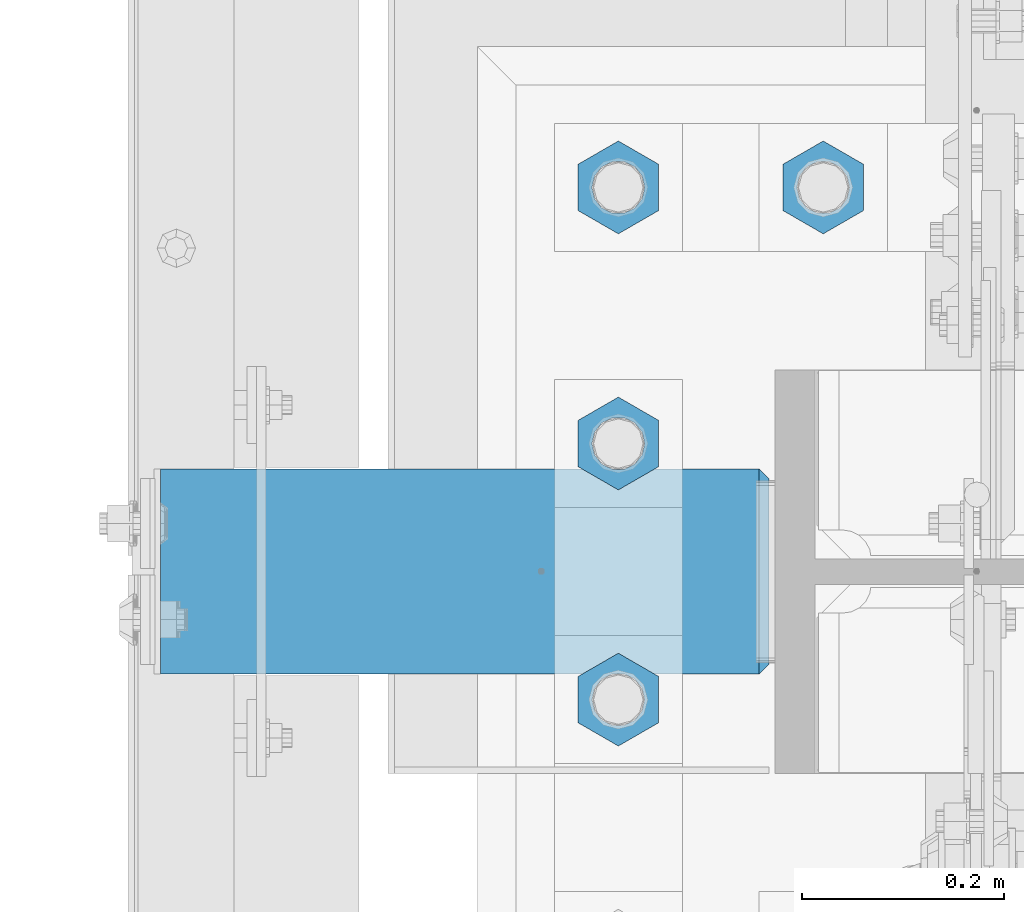
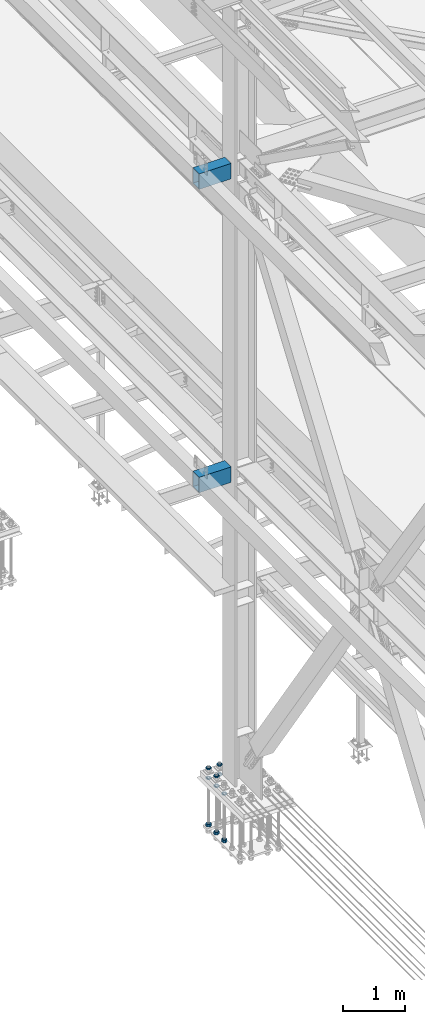
# One storey, part 2214 of 3843: 12 beams, 2 elements without a shape of their own.
"""IFC2X3 building model written with IfcOpenShell, lengths in millimetres."""

from ifc_helpers import new_model, si_unit, frame, origin_with_axes, place, context, subcontext, project, spatial, faceted_brep, material, type_object, element, aggregate, save


model = new_model("IFC2X3")

# Units and contexts
model_context = context("Model", 3, precision=1e-05, world=origin_with_axes())
body_context = subcontext(model_context, "Body", "Model", "MODEL_VIEW")
ifc_project = project(units=[si_unit("LENGTHUNIT", "METRE", prefix="MILLI"), si_unit("AREAUNIT", "SQUARE_METRE"), si_unit("VOLUMEUNIT", "CUBIC_METRE"), si_unit("MASSUNIT", "GRAM", prefix="KILO"), si_unit("TIMEUNIT", "SECOND"), si_unit("PLANEANGLEUNIT", "RADIAN"), si_unit("SOLIDANGLEUNIT", "STERADIAN"), si_unit("THERMODYNAMICTEMPERATUREUNIT", "DEGREE_CELSIUS"), si_unit("LUMINOUSINTENSITYUNIT", "LUMEN")], contexts=[model_context])

# Site, building, storey
site_placement = place(None, origin_with_axes())
site = spatial("IfcSite", under=ifc_project, at=site_placement, CompositionType="ELEMENT")
building_placement = place(site_placement, origin_with_axes())
building = spatial("IfcBuilding", under=site, at=building_placement, Name="Undefined", CompositionType="ELEMENT")
storey_placement = place(building_placement, origin_with_axes())
storey = spatial("IfcBuildingStorey", under=building, at=storey_placement, Name="Undefined", CompositionType="ELEMENT", Elevation=0.0)

# Assembly, beams
assembly_1_placement = place(storey_placement, origin_with_axes())
assembly_1 = element("IfcElementAssembly", 1, at=assembly_1_placement, inside=storey, Name="TEMPLATE", AssemblyPlace="NOTDEFINED", PredefinedType="RIGID_FRAME")
ifc_material_1 = material(Name="STEEL/A572-50")
beam_type_1 = type_object("IfcBeamType", Name="2_HALF_NUT", PredefinedType="NOTDEFINED")
beam_1_placement = place(assembly_1_placement, frame((36220.4, 58788.3, 30060.9), z_axis=(-1.0, 0.0, 0.0), x_axis=(0.0, 0.0, -1.0)))
beam_1 = element("IfcBeam", 2, at=beam_1_placement, type_object=beam_type_1, material=ifc_material_1, Name="NUT", ObjectType="2_HALF_NUT", context=body_context, shape_type="Brep", body=[
    faceted_brep([(0.0, -46.0369987487793, 0.0), (0.0, -23.0184993743896, -39.869213104248), (25.4000000000015, -23.0184993743896, -39.869213104248), (25.4000000000015, -46.0369987487793, 0.0), (0.0, 23.0184993743896, -39.869213104248), (25.4000000000015, 23.0184993743896, -39.869213104248), (0.0, 46.0369987487793, 0.0), (25.4000000000015, 46.0369987487793, 0.0), (0.0, 23.0184993743896, 39.869213104248), (25.4000000000015, 23.0184993743896, 39.869213104248), (0.0, -23.0184993743896, 39.869213104248), (25.4000000000015, -23.0184993743896, 39.869213104248), (0.0, 0.0, 26.1940002441406), (0.0, 11.3650617044477, 23.5999013092805), (25.4000000000015, 11.3650617044477, 23.5999013092805), (25.4000000000015, 0.0, 26.1940002441406), (0.0, 20.4791109456419, 16.3316083006721), (25.4000000000015, 20.4791109456419, 16.3316083006721), (0.0, 25.5370200498292, 5.82867859874386), (25.4000000000015, 25.5370200498292, 5.82867859874386), (0.0, 25.5370200498292, -5.82867859874386), (25.4000000000015, 25.5370200498292, -5.82867859874386), (0.0, 20.4791109456419, -16.3316083006721), (25.4000000000015, 20.4791109456419, -16.3316083006721), (0.0, 11.3650617044477, -23.5999013092805), (25.4000000000015, 11.3650617044477, -23.5999013092805), (0.0, 0.0, -26.1940002441406), (25.4000000000015, 0.0, -26.1940002441406), (0.0, -11.3650617044477, -23.5999013092805), (25.4000000000015, -11.3650617044477, -23.5999013092805), (0.0, -20.4791109456419, -16.3316083006721), (25.4000000000015, -20.4791109456419, -16.3316083006721), (0.0, -25.5370200498292, -5.82867859874386), (25.4000000000015, -25.5370200498292, -5.82867859874386), (0.0, -25.5370200498292, 5.82867859874386), (25.4000000000015, -25.5370200498292, 5.82867859874386), (0.0, -20.4791109456419, 16.3316083006721), (25.4000000000015, -20.4791109456419, 16.3316083006721), (0.0, -11.3650617044477, 23.5999013092805), (25.4000000000015, -11.3650617044477, 23.5999013092805)], [[[0, 1, 2, 3]], [[1, 4, 5, 2]], [[4, 6, 7, 5]], [[6, 8, 9, 7]], [[8, 10, 11, 9]], [[10, 0, 3, 11]], [[12, 13, 14, 15]], [[13, 16, 17, 14]], [[16, 18, 19, 17]], [[18, 20, 21, 19]], [[20, 22, 23, 21]], [[22, 24, 25, 23]], [[24, 26, 27, 25]], [[26, 28, 29, 27]], [[28, 30, 31, 29]], [[30, 32, 33, 31]], [[32, 34, 35, 33]], [[34, 36, 37, 35]], [[36, 38, 39, 37]], [[38, 12, 15, 39]], [[5, 7, 9, 11, 3, 2], [17, 19, 21, 23, 25, 27, 29, 31, 33, 35, 37, 39, 15, 14]], [[10, 8, 6, 4, 1, 0], [38, 36, 34, 32, 30, 28, 26, 24, 22, 20, 18, 16, 13, 12]]]),
])
beam_2_placement = place(assembly_1_placement, frame((36220.4, 59042.3, 30060.9), z_axis=(1.0, 0.0, 0.0), x_axis=(0.0, 0.0, -1.0)))
beam_2 = element("IfcBeam", 3, at=beam_2_placement, type_object=beam_type_1, material=ifc_material_1, Name="NUT", ObjectType="2_HALF_NUT", context=body_context, shape_type="Brep", body=[
    faceted_brep([(0.0, -46.0369987487793, 0.0), (0.0, -23.0184993743896, -39.869213104248), (25.4000000000015, -23.0184993743896, -39.869213104248), (25.4000000000015, -46.0369987487793, 0.0), (0.0, 23.0184993743896, -39.869213104248), (25.4000000000015, 23.0184993743896, -39.869213104248), (0.0, 46.0369987487793, 0.0), (25.4000000000015, 46.0369987487793, 0.0), (0.0, 23.0184993743896, 39.869213104248), (25.4000000000015, 23.0184993743896, 39.869213104248), (0.0, -23.0184993743896, 39.869213104248), (25.4000000000015, -23.0184993743896, 39.869213104248), (0.0, 0.0, 26.1940002441406), (0.0, 11.3650617044477, 23.5999013092805), (25.4000000000015, 11.3650617044477, 23.5999013092805), (25.4000000000015, 0.0, 26.1940002441406), (0.0, 20.4791109456419, 16.3316083006721), (25.4000000000015, 20.4791109456419, 16.3316083006721), (0.0, 25.5370200498292, 5.82867859874386), (25.4000000000015, 25.5370200498292, 5.82867859874386), (0.0, 25.5370200498292, -5.82867859874386), (25.4000000000015, 25.5370200498292, -5.82867859874386), (0.0, 20.4791109456419, -16.3316083006721), (25.4000000000015, 20.4791109456419, -16.3316083006721), (0.0, 11.3650617044477, -23.5999013092805), (25.4000000000015, 11.3650617044477, -23.5999013092805), (0.0, 0.0, -26.1940002441406), (25.4000000000015, 0.0, -26.1940002441406), (0.0, -11.3650617044477, -23.5999013092805), (25.4000000000015, -11.3650617044477, -23.5999013092805), (0.0, -20.4791109456419, -16.3316083006721), (25.4000000000015, -20.4791109456419, -16.3316083006721), (0.0, -25.5370200498292, -5.82867859874386), (25.4000000000015, -25.5370200498292, -5.82867859874386), (0.0, -25.5370200498292, 5.82867859874386), (25.4000000000015, -25.5370200498292, 5.82867859874386), (0.0, -20.4791109456419, 16.3316083006721), (25.4000000000015, -20.4791109456419, 16.3316083006721), (0.0, -11.3650617044477, 23.5999013092805), (25.4000000000015, -11.3650617044477, 23.5999013092805)], [[[0, 1, 2, 3]], [[1, 4, 5, 2]], [[4, 6, 7, 5]], [[6, 8, 9, 7]], [[8, 10, 11, 9]], [[10, 0, 3, 11]], [[12, 13, 14, 15]], [[13, 16, 17, 14]], [[16, 18, 19, 17]], [[18, 20, 21, 19]], [[20, 22, 23, 21]], [[22, 24, 25, 23]], [[24, 26, 27, 25]], [[26, 28, 29, 27]], [[28, 30, 31, 29]], [[30, 32, 33, 31]], [[32, 34, 35, 33]], [[34, 36, 37, 35]], [[36, 38, 39, 37]], [[38, 12, 15, 39]], [[5, 7, 9, 11, 3, 2], [17, 19, 21, 23, 25, 27, 29, 31, 33, 35, 37, 39, 15, 14]], [[10, 8, 6, 4, 1, 0], [38, 36, 34, 32, 30, 28, 26, 24, 22, 20, 18, 16, 13, 12]]]),
])
beam_3_placement = place(assembly_1_placement, frame((36423.6, 59296.3, 30060.9), z_axis=(1.0, 0.0, 0.0), x_axis=(0.0, 0.0, -1.0)))
beam_3 = element("IfcBeam", 4, at=beam_3_placement, type_object=beam_type_1, material=ifc_material_1, Name="NUT", ObjectType="2_HALF_NUT", context=body_context, shape_type="Brep", body=[
    faceted_brep([(0.0, -46.0369987487793, 0.0), (0.0, -23.0184993743896, -39.869213104248), (25.4000000000015, -23.0184993743896, -39.869213104248), (25.4000000000015, -46.0369987487793, 0.0), (0.0, 23.0184993743896, -39.869213104248), (25.4000000000015, 23.0184993743896, -39.869213104248), (0.0, 46.0369987487793, 0.0), (25.4000000000015, 46.0369987487793, 0.0), (0.0, 23.0184993743896, 39.869213104248), (25.4000000000015, 23.0184993743896, 39.869213104248), (0.0, -23.0184993743896, 39.869213104248), (25.4000000000015, -23.0184993743896, 39.869213104248), (0.0, 0.0, 26.1940002441406), (0.0, 11.3650617044477, 23.5999013092805), (25.4000000000015, 11.3650617044477, 23.5999013092805), (25.4000000000015, 0.0, 26.1940002441406), (0.0, 20.4791109456419, 16.3316083006721), (25.4000000000015, 20.4791109456419, 16.3316083006721), (0.0, 25.5370200498292, 5.82867859874386), (25.4000000000015, 25.5370200498292, 5.82867859874386), (0.0, 25.5370200498292, -5.82867859874386), (25.4000000000015, 25.5370200498292, -5.82867859874386), (0.0, 20.4791109456419, -16.3316083006721), (25.4000000000015, 20.4791109456419, -16.3316083006721), (0.0, 11.3650617044477, -23.5999013092805), (25.4000000000015, 11.3650617044477, -23.5999013092805), (0.0, 0.0, -26.1940002441406), (25.4000000000015, 0.0, -26.1940002441406), (0.0, -11.3650617044477, -23.5999013092805), (25.4000000000015, -11.3650617044477, -23.5999013092805), (0.0, -20.4791109456419, -16.3316083006721), (25.4000000000015, -20.4791109456419, -16.3316083006721), (0.0, -25.5370200498292, -5.82867859874386), (25.4000000000015, -25.5370200498292, -5.82867859874386), (0.0, -25.5370200498292, 5.82867859874386), (25.4000000000015, -25.5370200498292, 5.82867859874386), (0.0, -20.4791109456419, 16.3316083006721), (25.4000000000015, -20.4791109456419, 16.3316083006721), (0.0, -11.3650617044477, 23.5999013092805), (25.4000000000015, -11.3650617044477, 23.5999013092805)], [[[0, 1, 2, 3]], [[1, 4, 5, 2]], [[4, 6, 7, 5]], [[6, 8, 9, 7]], [[8, 10, 11, 9]], [[10, 0, 3, 11]], [[12, 13, 14, 15]], [[13, 16, 17, 14]], [[16, 18, 19, 17]], [[18, 20, 21, 19]], [[20, 22, 23, 21]], [[22, 24, 25, 23]], [[24, 26, 27, 25]], [[26, 28, 29, 27]], [[28, 30, 31, 29]], [[30, 32, 33, 31]], [[32, 34, 35, 33]], [[34, 36, 37, 35]], [[36, 38, 39, 37]], [[38, 12, 15, 39]], [[5, 7, 9, 11, 3, 2], [17, 19, 21, 23, 25, 27, 29, 31, 33, 35, 37, 39, 15, 14]], [[10, 8, 6, 4, 1, 0], [38, 36, 34, 32, 30, 28, 26, 24, 22, 20, 18, 16, 13, 12]]]),
])
beam_4_placement = place(assembly_1_placement, frame((36220.4, 59296.3, 30060.9), z_axis=(1.0, 0.0, 0.0), x_axis=(0.0, 0.0, -1.0)))
beam_4 = element("IfcBeam", 5, at=beam_4_placement, type_object=beam_type_1, material=ifc_material_1, Name="NUT", ObjectType="2_HALF_NUT", context=body_context, shape_type="Brep", body=[
    faceted_brep([(0.0, -46.0369987487793, 0.0), (0.0, -23.0184993743896, -39.869213104248), (25.4000000000015, -23.0184993743896, -39.869213104248), (25.4000000000015, -46.0369987487793, 0.0), (0.0, 23.0184993743896, -39.869213104248), (25.4000000000015, 23.0184993743896, -39.869213104248), (0.0, 46.0369987487793, 0.0), (25.4000000000015, 46.0369987487793, 0.0), (0.0, 23.0184993743896, 39.869213104248), (25.4000000000015, 23.0184993743896, 39.869213104248), (0.0, -23.0184993743896, 39.869213104248), (25.4000000000015, -23.0184993743896, 39.869213104248), (0.0, 0.0, 26.1940002441406), (0.0, 11.3650617044477, 23.5999013092805), (25.4000000000015, 11.3650617044477, 23.5999013092805), (25.4000000000015, 0.0, 26.1940002441406), (0.0, 20.4791109456419, 16.3316083006721), (25.4000000000015, 20.4791109456419, 16.3316083006721), (0.0, 25.5370200498292, 5.82867859874386), (25.4000000000015, 25.5370200498292, 5.82867859874386), (0.0, 25.5370200498292, -5.82867859874386), (25.4000000000015, 25.5370200498292, -5.82867859874386), (0.0, 20.4791109456419, -16.3316083006721), (25.4000000000015, 20.4791109456419, -16.3316083006721), (0.0, 11.3650617044477, -23.5999013092805), (25.4000000000015, 11.3650617044477, -23.5999013092805), (0.0, 0.0, -26.1940002441406), (25.4000000000015, 0.0, -26.1940002441406), (0.0, -11.3650617044477, -23.5999013092805), (25.4000000000015, -11.3650617044477, -23.5999013092805), (0.0, -20.4791109456419, -16.3316083006721), (25.4000000000015, -20.4791109456419, -16.3316083006721), (0.0, -25.5370200498292, -5.82867859874386), (25.4000000000015, -25.5370200498292, -5.82867859874386), (0.0, -25.5370200498292, 5.82867859874386), (25.4000000000015, -25.5370200498292, 5.82867859874386), (0.0, -20.4791109456419, 16.3316083006721), (25.4000000000015, -20.4791109456419, 16.3316083006721), (0.0, -11.3650617044477, 23.5999013092805), (25.4000000000015, -11.3650617044477, 23.5999013092805)], [[[0, 1, 2, 3]], [[1, 4, 5, 2]], [[4, 6, 7, 5]], [[6, 8, 9, 7]], [[8, 10, 11, 9]], [[10, 0, 3, 11]], [[12, 13, 14, 15]], [[13, 16, 17, 14]], [[16, 18, 19, 17]], [[18, 20, 21, 19]], [[20, 22, 23, 21]], [[22, 24, 25, 23]], [[24, 26, 27, 25]], [[26, 28, 29, 27]], [[28, 30, 31, 29]], [[30, 32, 33, 31]], [[32, 34, 35, 33]], [[34, 36, 37, 35]], [[36, 38, 39, 37]], [[38, 12, 15, 39]], [[5, 7, 9, 11, 3, 2], [17, 19, 21, 23, 25, 27, 29, 31, 33, 35, 37, 39, 15, 14]], [[10, 8, 6, 4, 1, 0], [38, 36, 34, 32, 30, 28, 26, 24, 22, 20, 18, 16, 13, 12]]]),
])
beam_5_placement = place(assembly_1_placement, frame((36423.6, 59296.3, 30257.75), z_axis=(1.0, 0.0, 0.0), x_axis=(0.0, 0.0, -1.0)))
beam_5 = element("IfcBeam", 6, at=beam_5_placement, type_object=beam_type_1, material=ifc_material_1, Name="NUT", ObjectType="2_HALF_NUT", context=body_context, shape_type="Brep", body=[
    faceted_brep([(0.0, -46.0369987487793, 0.0), (0.0, -23.0184993743896, -39.869213104248), (25.4000000000015, -23.0184993743896, -39.869213104248), (25.4000000000015, -46.0369987487793, 0.0), (0.0, 23.0184993743896, -39.869213104248), (25.4000000000015, 23.0184993743896, -39.869213104248), (0.0, 46.0369987487793, 0.0), (25.4000000000015, 46.0369987487793, 0.0), (0.0, 23.0184993743896, 39.869213104248), (25.4000000000015, 23.0184993743896, 39.869213104248), (0.0, -23.0184993743896, 39.869213104248), (25.4000000000015, -23.0184993743896, 39.869213104248), (0.0, 0.0, 26.1940002441406), (0.0, 11.3650617044477, 23.5999013092805), (25.4000000000015, 11.3650617044477, 23.5999013092805), (25.4000000000015, 0.0, 26.1940002441406), (0.0, 20.4791109456419, 16.3316083006721), (25.4000000000015, 20.4791109456419, 16.3316083006721), (0.0, 25.5370200498292, 5.82867859874386), (25.4000000000015, 25.5370200498292, 5.82867859874386), (0.0, 25.5370200498292, -5.82867859874386), (25.4000000000015, 25.5370200498292, -5.82867859874386), (0.0, 20.4791109456419, -16.3316083006721), (25.4000000000015, 20.4791109456419, -16.3316083006721), (0.0, 11.3650617044477, -23.5999013092805), (25.4000000000015, 11.3650617044477, -23.5999013092805), (0.0, 0.0, -26.1940002441406), (25.4000000000015, 0.0, -26.1940002441406), (0.0, -11.3650617044477, -23.5999013092805), (25.4000000000015, -11.3650617044477, -23.5999013092805), (0.0, -20.4791109456419, -16.3316083006721), (25.4000000000015, -20.4791109456419, -16.3316083006721), (0.0, -25.5370200498292, -5.82867859874386), (25.4000000000015, -25.5370200498292, -5.82867859874386), (0.0, -25.5370200498292, 5.82867859874386), (25.4000000000015, -25.5370200498292, 5.82867859874386), (0.0, -20.4791109456419, 16.3316083006721), (25.4000000000015, -20.4791109456419, 16.3316083006721), (0.0, -11.3650617044477, 23.5999013092805), (25.4000000000015, -11.3650617044477, 23.5999013092805)], [[[0, 1, 2, 3]], [[1, 4, 5, 2]], [[4, 6, 7, 5]], [[6, 8, 9, 7]], [[8, 10, 11, 9]], [[10, 0, 3, 11]], [[12, 13, 14, 15]], [[13, 16, 17, 14]], [[16, 18, 19, 17]], [[18, 20, 21, 19]], [[20, 22, 23, 21]], [[22, 24, 25, 23]], [[24, 26, 27, 25]], [[26, 28, 29, 27]], [[28, 30, 31, 29]], [[30, 32, 33, 31]], [[32, 34, 35, 33]], [[34, 36, 37, 35]], [[36, 38, 39, 37]], [[38, 12, 15, 39]], [[5, 7, 9, 11, 3, 2], [17, 19, 21, 23, 25, 27, 29, 31, 33, 35, 37, 39, 15, 14]], [[10, 8, 6, 4, 1, 0], [38, 36, 34, 32, 30, 28, 26, 24, 22, 20, 18, 16, 13, 12]]]),
])
beam_6_placement = place(assembly_1_placement, frame((36220.4, 59296.3, 30257.75), z_axis=(1.0, 0.0, 0.0), x_axis=(0.0, 0.0, -1.0)))
beam_6 = element("IfcBeam", 7, at=beam_6_placement, type_object=beam_type_1, material=ifc_material_1, Name="NUT", ObjectType="2_HALF_NUT", context=body_context, shape_type="Brep", body=[
    faceted_brep([(0.0, -46.0369987487793, 0.0), (0.0, -23.0184993743896, -39.869213104248), (25.4000000000015, -23.0184993743896, -39.869213104248), (25.4000000000015, -46.0369987487793, 0.0), (0.0, 23.0184993743896, -39.869213104248), (25.4000000000015, 23.0184993743896, -39.869213104248), (0.0, 46.0369987487793, 0.0), (25.4000000000015, 46.0369987487793, 0.0), (0.0, 23.0184993743896, 39.869213104248), (25.4000000000015, 23.0184993743896, 39.869213104248), (0.0, -23.0184993743896, 39.869213104248), (25.4000000000015, -23.0184993743896, 39.869213104248), (0.0, 0.0, 26.1940002441406), (0.0, 11.3650617044477, 23.5999013092805), (25.4000000000015, 11.3650617044477, 23.5999013092805), (25.4000000000015, 0.0, 26.1940002441406), (0.0, 20.4791109456419, 16.3316083006721), (25.4000000000015, 20.4791109456419, 16.3316083006721), (0.0, 25.5370200498292, 5.82867859874386), (25.4000000000015, 25.5370200498292, 5.82867859874386), (0.0, 25.5370200498292, -5.82867859874386), (25.4000000000015, 25.5370200498292, -5.82867859874386), (0.0, 20.4791109456419, -16.3316083006721), (25.4000000000015, 20.4791109456419, -16.3316083006721), (0.0, 11.3650617044477, -23.5999013092805), (25.4000000000015, 11.3650617044477, -23.5999013092805), (0.0, 0.0, -26.1940002441406), (25.4000000000015, 0.0, -26.1940002441406), (0.0, -11.3650617044477, -23.5999013092805), (25.4000000000015, -11.3650617044477, -23.5999013092805), (0.0, -20.4791109456419, -16.3316083006721), (25.4000000000015, -20.4791109456419, -16.3316083006721), (0.0, -25.5370200498292, -5.82867859874386), (25.4000000000015, -25.5370200498292, -5.82867859874386), (0.0, -25.5370200498292, 5.82867859874386), (25.4000000000015, -25.5370200498292, 5.82867859874386), (0.0, -20.4791109456419, 16.3316083006721), (25.4000000000015, -20.4791109456419, 16.3316083006721), (0.0, -11.3650617044477, 23.5999013092805), (25.4000000000015, -11.3650617044477, 23.5999013092805)], [[[0, 1, 2, 3]], [[1, 4, 5, 2]], [[4, 6, 7, 5]], [[6, 8, 9, 7]], [[8, 10, 11, 9]], [[10, 0, 3, 11]], [[12, 13, 14, 15]], [[13, 16, 17, 14]], [[16, 18, 19, 17]], [[18, 20, 21, 19]], [[20, 22, 23, 21]], [[22, 24, 25, 23]], [[24, 26, 27, 25]], [[26, 28, 29, 27]], [[28, 30, 31, 29]], [[30, 32, 33, 31]], [[32, 34, 35, 33]], [[34, 36, 37, 35]], [[36, 38, 39, 37]], [[38, 12, 15, 39]], [[5, 7, 9, 11, 3, 2], [17, 19, 21, 23, 25, 27, 29, 31, 33, 35, 37, 39, 15, 14]], [[10, 8, 6, 4, 1, 0], [38, 36, 34, 32, 30, 28, 26, 24, 22, 20, 18, 16, 13, 12]]]),
])
beam_7_placement = place(assembly_1_placement, frame((36220.4, 59042.3, 30257.75), z_axis=(1.0, 0.0, 0.0), x_axis=(0.0, 0.0, -1.0)))
beam_7 = element("IfcBeam", 8, at=beam_7_placement, type_object=beam_type_1, material=ifc_material_1, Name="NUT", ObjectType="2_HALF_NUT", context=body_context, shape_type="Brep", body=[
    faceted_brep([(0.0, -46.0369987487793, 0.0), (0.0, -23.0184993743896, -39.869213104248), (25.4000000000015, -23.0184993743896, -39.869213104248), (25.4000000000015, -46.0369987487793, 0.0), (0.0, 23.0184993743896, -39.869213104248), (25.4000000000015, 23.0184993743896, -39.869213104248), (0.0, 46.0369987487793, 0.0), (25.4000000000015, 46.0369987487793, 0.0), (0.0, 23.0184993743896, 39.869213104248), (25.4000000000015, 23.0184993743896, 39.869213104248), (0.0, -23.0184993743896, 39.869213104248), (25.4000000000015, -23.0184993743896, 39.869213104248), (0.0, 0.0, 26.1940002441406), (0.0, 11.3650617044477, 23.5999013092805), (25.4000000000015, 11.3650617044477, 23.5999013092805), (25.4000000000015, 0.0, 26.1940002441406), (0.0, 20.4791109456419, 16.3316083006721), (25.4000000000015, 20.4791109456419, 16.3316083006721), (0.0, 25.5370200498292, 5.82867859874386), (25.4000000000015, 25.5370200498292, 5.82867859874386), (0.0, 25.5370200498292, -5.82867859874386), (25.4000000000015, 25.5370200498292, -5.82867859874386), (0.0, 20.4791109456419, -16.3316083006721), (25.4000000000015, 20.4791109456419, -16.3316083006721), (0.0, 11.3650617044477, -23.5999013092805), (25.4000000000015, 11.3650617044477, -23.5999013092805), (0.0, 0.0, -26.1940002441406), (25.4000000000015, 0.0, -26.1940002441406), (0.0, -11.3650617044477, -23.5999013092805), (25.4000000000015, -11.3650617044477, -23.5999013092805), (0.0, -20.4791109456419, -16.3316083006721), (25.4000000000015, -20.4791109456419, -16.3316083006721), (0.0, -25.5370200498292, -5.82867859874386), (25.4000000000015, -25.5370200498292, -5.82867859874386), (0.0, -25.5370200498292, 5.82867859874386), (25.4000000000015, -25.5370200498292, 5.82867859874386), (0.0, -20.4791109456419, 16.3316083006721), (25.4000000000015, -20.4791109456419, 16.3316083006721), (0.0, -11.3650617044477, 23.5999013092805), (25.4000000000015, -11.3650617044477, 23.5999013092805)], [[[0, 1, 2, 3]], [[1, 4, 5, 2]], [[4, 6, 7, 5]], [[6, 8, 9, 7]], [[8, 10, 11, 9]], [[10, 0, 3, 11]], [[12, 13, 14, 15]], [[13, 16, 17, 14]], [[16, 18, 19, 17]], [[18, 20, 21, 19]], [[20, 22, 23, 21]], [[22, 24, 25, 23]], [[24, 26, 27, 25]], [[26, 28, 29, 27]], [[28, 30, 31, 29]], [[30, 32, 33, 31]], [[32, 34, 35, 33]], [[34, 36, 37, 35]], [[36, 38, 39, 37]], [[38, 12, 15, 39]], [[5, 7, 9, 11, 3, 2], [17, 19, 21, 23, 25, 27, 29, 31, 33, 35, 37, 39, 15, 14]], [[10, 8, 6, 4, 1, 0], [38, 36, 34, 32, 30, 28, 26, 24, 22, 20, 18, 16, 13, 12]]]),
])
beam_type_2 = type_object("IfcBeamType", Name="2_HEAVY_HEX_NUT", PredefinedType="NOTDEFINED")
beam_8_placement = place(assembly_1_placement, frame((36220.4, 59296.3, 29159.2), z_axis=(1.0, 0.0, 0.0), x_axis=(0.0, 0.0, -1.0)))
beam_8 = element("IfcBeam", 9, at=beam_8_placement, type_object=beam_type_2, material=ifc_material_1, Name="NUT", ObjectType="2_HEAVY_HEX_NUT", context=body_context, shape_type="Brep", body=[
    faceted_brep([(0.0, -46.0369987487793, 0.0), (0.0, -23.0184993743896, -39.869213104248), (50.7999999999993, -23.0184993743896, -39.869213104248), (50.7999999999993, -46.0369987487793, 0.0), (0.0, 23.0184993743896, -39.869213104248), (50.7999999999993, 23.0184993743896, -39.869213104248), (0.0, 46.0369987487793, 0.0), (50.7999999999993, 46.0369987487793, 0.0), (0.0, 23.0184993743896, 39.869213104248), (50.7999999999993, 23.0184993743896, 39.869213104248), (0.0, -23.0184993743896, 39.869213104248), (50.7999999999993, -23.0184993743896, 39.869213104248), (0.0, 0.0, 26.1940002441406), (0.0, 11.3650617044477, 23.5999013092805), (50.7999999999993, 11.3650617044477, 23.5999013092805), (50.7999999999993, 0.0, 26.1940002441406), (0.0, 20.4791109456419, 16.3316083006721), (50.7999999999993, 20.4791109456419, 16.3316083006721), (0.0, 25.5370200498292, 5.82867859874386), (50.7999999999993, 25.5370200498292, 5.82867859874386), (0.0, 25.5370200498292, -5.82867859874386), (50.7999999999993, 25.5370200498292, -5.82867859874386), (0.0, 20.4791109456419, -16.3316083006721), (50.7999999999993, 20.4791109456419, -16.3316083006721), (0.0, 11.3650617044477, -23.5999013092805), (50.7999999999993, 11.3650617044477, -23.5999013092805), (0.0, 0.0, -26.1940002441406), (50.7999999999993, 0.0, -26.1940002441406), (0.0, -11.3650617044477, -23.5999013092805), (50.7999999999993, -11.3650617044477, -23.5999013092805), (0.0, -20.4791109456419, -16.3316083006721), (50.7999999999993, -20.4791109456419, -16.3316083006721), (0.0, -25.5370200498292, -5.82867859874386), (50.7999999999993, -25.5370200498292, -5.82867859874386), (0.0, -25.5370200498292, 5.82867859874386), (50.7999999999993, -25.5370200498292, 5.82867859874386), (0.0, -20.4791109456419, 16.3316083006721), (50.7999999999993, -20.4791109456419, 16.3316083006721), (0.0, -11.3650617044477, 23.5999013092805), (50.7999999999993, -11.3650617044477, 23.5999013092805)], [[[0, 1, 2, 3]], [[1, 4, 5, 2]], [[4, 6, 7, 5]], [[6, 8, 9, 7]], [[8, 10, 11, 9]], [[10, 0, 3, 11]], [[12, 13, 14, 15]], [[13, 16, 17, 14]], [[16, 18, 19, 17]], [[18, 20, 21, 19]], [[20, 22, 23, 21]], [[22, 24, 25, 23]], [[24, 26, 27, 25]], [[26, 28, 29, 27]], [[28, 30, 31, 29]], [[30, 32, 33, 31]], [[32, 34, 35, 33]], [[34, 36, 37, 35]], [[36, 38, 39, 37]], [[38, 12, 15, 39]], [[5, 7, 9, 11, 3, 2], [17, 19, 21, 23, 25, 27, 29, 31, 33, 35, 37, 39, 15, 14]], [[10, 8, 6, 4, 1, 0], [38, 36, 34, 32, 30, 28, 26, 24, 22, 20, 18, 16, 13, 12]]]),
])
beam_9_placement = place(assembly_1_placement, frame((36220.4, 59042.3, 29159.2), z_axis=(1.0, 0.0, 0.0), x_axis=(0.0, 0.0, -1.0)))
beam_9 = element("IfcBeam", 10, at=beam_9_placement, type_object=beam_type_2, material=ifc_material_1, Name="NUT", ObjectType="2_HEAVY_HEX_NUT", context=body_context, shape_type="Brep", body=[
    faceted_brep([(0.0, -46.0369987487793, 0.0), (0.0, -23.0184993743896, -39.869213104248), (50.7999999999993, -23.0184993743896, -39.869213104248), (50.7999999999993, -46.0369987487793, 0.0), (0.0, 23.0184993743896, -39.869213104248), (50.7999999999993, 23.0184993743896, -39.869213104248), (0.0, 46.0369987487793, 0.0), (50.7999999999993, 46.0369987487793, 0.0), (0.0, 23.0184993743896, 39.869213104248), (50.7999999999993, 23.0184993743896, 39.869213104248), (0.0, -23.0184993743896, 39.869213104248), (50.7999999999993, -23.0184993743896, 39.869213104248), (0.0, 0.0, 26.1940002441406), (0.0, 11.3650617044477, 23.5999013092805), (50.7999999999993, 11.3650617044477, 23.5999013092805), (50.7999999999993, 0.0, 26.1940002441406), (0.0, 20.4791109456419, 16.3316083006721), (50.7999999999993, 20.4791109456419, 16.3316083006721), (0.0, 25.5370200498292, 5.82867859874386), (50.7999999999993, 25.5370200498292, 5.82867859874386), (0.0, 25.5370200498292, -5.82867859874386), (50.7999999999993, 25.5370200498292, -5.82867859874386), (0.0, 20.4791109456419, -16.3316083006721), (50.7999999999993, 20.4791109456419, -16.3316083006721), (0.0, 11.3650617044477, -23.5999013092805), (50.7999999999993, 11.3650617044477, -23.5999013092805), (0.0, 0.0, -26.1940002441406), (50.7999999999993, 0.0, -26.1940002441406), (0.0, -11.3650617044477, -23.5999013092805), (50.7999999999993, -11.3650617044477, -23.5999013092805), (0.0, -20.4791109456419, -16.3316083006721), (50.7999999999993, -20.4791109456419, -16.3316083006721), (0.0, -25.5370200498292, -5.82867859874386), (50.7999999999993, -25.5370200498292, -5.82867859874386), (0.0, -25.5370200498292, 5.82867859874386), (50.7999999999993, -25.5370200498292, 5.82867859874386), (0.0, -20.4791109456419, 16.3316083006721), (50.7999999999993, -20.4791109456419, 16.3316083006721), (0.0, -11.3650617044477, 23.5999013092805), (50.7999999999993, -11.3650617044477, 23.5999013092805)], [[[0, 1, 2, 3]], [[1, 4, 5, 2]], [[4, 6, 7, 5]], [[6, 8, 9, 7]], [[8, 10, 11, 9]], [[10, 0, 3, 11]], [[12, 13, 14, 15]], [[13, 16, 17, 14]], [[16, 18, 19, 17]], [[18, 20, 21, 19]], [[20, 22, 23, 21]], [[22, 24, 25, 23]], [[24, 26, 27, 25]], [[26, 28, 29, 27]], [[28, 30, 31, 29]], [[30, 32, 33, 31]], [[32, 34, 35, 33]], [[34, 36, 37, 35]], [[36, 38, 39, 37]], [[38, 12, 15, 39]], [[5, 7, 9, 11, 3, 2], [17, 19, 21, 23, 25, 27, 29, 31, 33, 35, 37, 39, 15, 14]], [[10, 8, 6, 4, 1, 0], [38, 36, 34, 32, 30, 28, 26, 24, 22, 20, 18, 16, 13, 12]]]),
])
beam_10_placement = place(assembly_1_placement, frame((36220.4, 58788.3, 29159.2), z_axis=(1.0, 0.0, 0.0), x_axis=(0.0, 0.0, -1.0)))
beam_10 = element("IfcBeam", 11, at=beam_10_placement, type_object=beam_type_2, material=ifc_material_1, Name="NUT", ObjectType="2_HEAVY_HEX_NUT", context=body_context, shape_type="Brep", body=[
    faceted_brep([(0.0, -46.0369987487793, 0.0), (0.0, -23.0184993743896, -39.869213104248), (50.7999999999993, -23.0184993743896, -39.869213104248), (50.7999999999993, -46.0369987487793, 0.0), (0.0, 23.0184993743896, -39.869213104248), (50.7999999999993, 23.0184993743896, -39.869213104248), (0.0, 46.0369987487793, 0.0), (50.7999999999993, 46.0369987487793, 0.0), (0.0, 23.0184993743896, 39.869213104248), (50.7999999999993, 23.0184993743896, 39.869213104248), (0.0, -23.0184993743896, 39.869213104248), (50.7999999999993, -23.0184993743896, 39.869213104248), (0.0, 0.0, 26.1940002441406), (0.0, 11.3650617044477, 23.5999013092805), (50.7999999999993, 11.3650617044477, 23.5999013092805), (50.7999999999993, 0.0, 26.1940002441406), (0.0, 20.4791109456419, 16.3316083006721), (50.7999999999993, 20.4791109456419, 16.3316083006721), (0.0, 25.5370200498292, 5.82867859874386), (50.7999999999993, 25.5370200498292, 5.82867859874386), (0.0, 25.5370200498292, -5.82867859874386), (50.7999999999993, 25.5370200498292, -5.82867859874386), (0.0, 20.4791109456419, -16.3316083006721), (50.7999999999993, 20.4791109456419, -16.3316083006721), (0.0, 11.3650617044477, -23.5999013092805), (50.7999999999993, 11.3650617044477, -23.5999013092805), (0.0, 0.0, -26.1940002441406), (50.7999999999993, 0.0, -26.1940002441406), (0.0, -11.3650617044477, -23.5999013092805), (50.7999999999993, -11.3650617044477, -23.5999013092805), (0.0, -20.4791109456419, -16.3316083006721), (50.7999999999993, -20.4791109456419, -16.3316083006721), (0.0, -25.5370200498292, -5.82867859874386), (50.7999999999993, -25.5370200498292, -5.82867859874386), (0.0, -25.5370200498292, 5.82867859874386), (50.7999999999993, -25.5370200498292, 5.82867859874386), (0.0, -20.4791109456419, 16.3316083006721), (50.7999999999993, -20.4791109456419, 16.3316083006721), (0.0, -11.3650617044477, 23.5999013092805), (50.7999999999993, -11.3650617044477, 23.5999013092805)], [[[0, 1, 2, 3]], [[1, 4, 5, 2]], [[4, 6, 7, 5]], [[6, 8, 9, 7]], [[8, 10, 11, 9]], [[10, 0, 3, 11]], [[12, 13, 14, 15]], [[13, 16, 17, 14]], [[16, 18, 19, 17]], [[18, 20, 21, 19]], [[20, 22, 23, 21]], [[22, 24, 25, 23]], [[24, 26, 27, 25]], [[26, 28, 29, 27]], [[28, 30, 31, 29]], [[30, 32, 33, 31]], [[32, 34, 35, 33]], [[34, 36, 37, 35]], [[36, 38, 39, 37]], [[38, 12, 15, 39]], [[5, 7, 9, 11, 3, 2], [17, 19, 21, 23, 25, 27, 29, 31, 33, 35, 37, 39, 15, 14]], [[10, 8, 6, 4, 1, 0], [38, 36, 34, 32, 30, 28, 26, 24, 22, 20, 18, 16, 13, 12]]]),
])
aggregate(assembly_1, [beam_8, beam_9, beam_10, beam_1, beam_2, beam_3, beam_4, beam_5, beam_6, beam_7])

assembly_2_placement = place(storey_placement, origin_with_axes())
assembly_2 = element("IfcElementAssembly", 12, at=assembly_2_placement, inside=storey, Name="COLUMN", AssemblyPlace="NOTDEFINED", PredefinedType="RIGID_FRAME")
ifc_material_2 = material()
beam_type_3 = type_object("IfcBeamType", Name="HSS12X8X3/8", PredefinedType="NOTDEFINED")
beam_11_placement = place(assembly_2_placement, frame((35760.025, 58915.3, 42214.8), z_axis=(0.0, 0.0, 1.0), x_axis=(1.0, 0.0, 0.0)))
beam_11 = element("IfcBeam", 13, at=beam_11_placement, type_object=beam_type_3, material=ifc_material_2, Name="GIRT", ObjectType="HSS12X8X3/8", context=body_context, shape_type="Brep", body=[
    faceted_brep([(609.600000000006, 92.0749999999971, 142.875), (609.600000000006, 92.0749999999971, -142.875), (600.075000000004, 101.600000000006, -152.400000000001), (600.075000000004, 101.600000000006, 152.400000000001), (609.600000000006, -92.0749999999971, -142.875), (600.075000000004, -101.600000000006, -152.400000000001), (609.600000000006, -92.0749999999971, 142.875), (600.075000000004, -101.600000000006, 152.400000000001), (6.35000000002037, 92.0749999999971, 142.875), (6.35000000002037, 92.0749999999971, -142.875), (6.35000000002037, -92.0749999999971, 142.875), (6.35000000002037, -92.0749999999971, -142.875), (6.35000000002037, -101.600000000006, -152.400000000001), (6.35000000002037, -101.600000000006, 152.400000000001), (6.35000000002037, 101.600000000006, 152.400000000001), (6.35000000002037, 101.600000000006, -152.400000000001)], [[[0, 1, 2, 3]], [[4, 5, 2, 1]], [[6, 7, 5, 4]], [[8, 9, 1, 0]], [[10, 8, 0, 6]], [[11, 10, 6, 4]], [[9, 11, 4, 1]], [[12, 13, 14, 15], [8, 10, 11, 9]], [[15, 14, 3, 2]], [[12, 15, 2, 5]], [[13, 12, 5, 7]], [[14, 13, 7, 3]], [[0, 3, 7, 6]]]),
])
beam_12_placement = place(assembly_2_placement, frame((35760.025, 58915.3, 36252.15), z_axis=(0.0, 0.0, 1.0), x_axis=(1.0, 0.0, 0.0)))
beam_12 = element("IfcBeam", 14, at=beam_12_placement, type_object=beam_type_3, material=ifc_material_2, Name="BEAM", ObjectType="HSS12X8X3/8", context=body_context, shape_type="Brep", body=[
    faceted_brep([(609.600000000006, 92.0749999999971, 142.875), (609.600000000006, 92.0749999999971, -142.875), (600.075000000004, 101.600000000006, -152.400000000001), (600.075000000004, 101.600000000006, 152.400000000001), (609.600000000006, -92.0749999999971, -142.875), (600.075000000004, -101.600000000006, -152.400000000001), (609.600000000006, -92.0749999999971, 142.875), (600.075000000004, -101.600000000006, 152.400000000001), (6.35000000002037, 92.0749999999971, 142.875), (6.35000000002037, 92.0749999999971, -142.875), (6.35000000002037, -92.0749999999971, 142.875), (6.35000000002037, -92.0749999999971, -142.875), (6.35000000002037, -101.600000000006, -152.400000000001), (6.35000000002037, -101.600000000006, 152.400000000001), (6.35000000002037, 101.600000000006, 152.400000000001), (6.35000000002037, 101.600000000006, -152.400000000001)], [[[0, 1, 2, 3]], [[4, 5, 2, 1]], [[6, 7, 5, 4]], [[8, 9, 1, 0]], [[10, 8, 0, 6]], [[11, 10, 6, 4]], [[9, 11, 4, 1]], [[12, 13, 14, 15], [8, 10, 11, 9]], [[15, 14, 3, 2]], [[12, 15, 2, 5]], [[13, 12, 5, 7]], [[14, 13, 7, 3]], [[0, 3, 7, 6]]]),
])
aggregate(assembly_2, [beam_11, beam_12])

save(model, "model.ifc")
